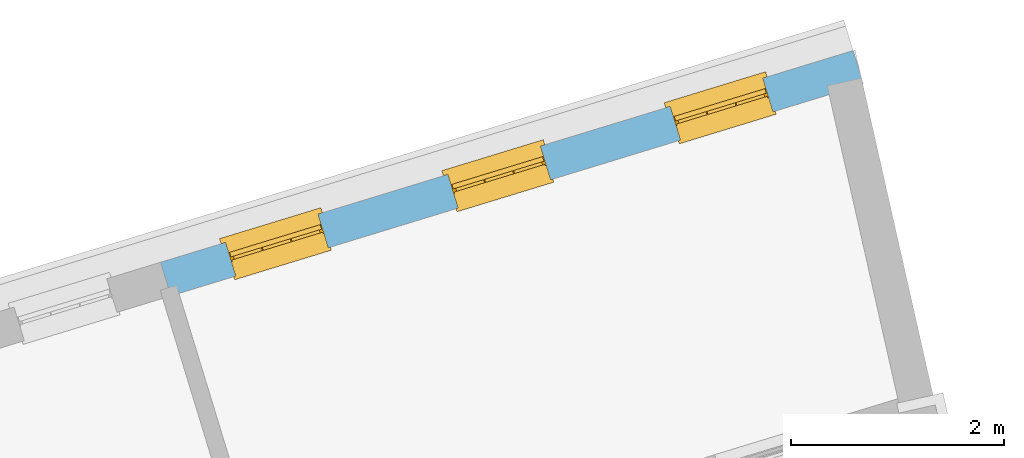
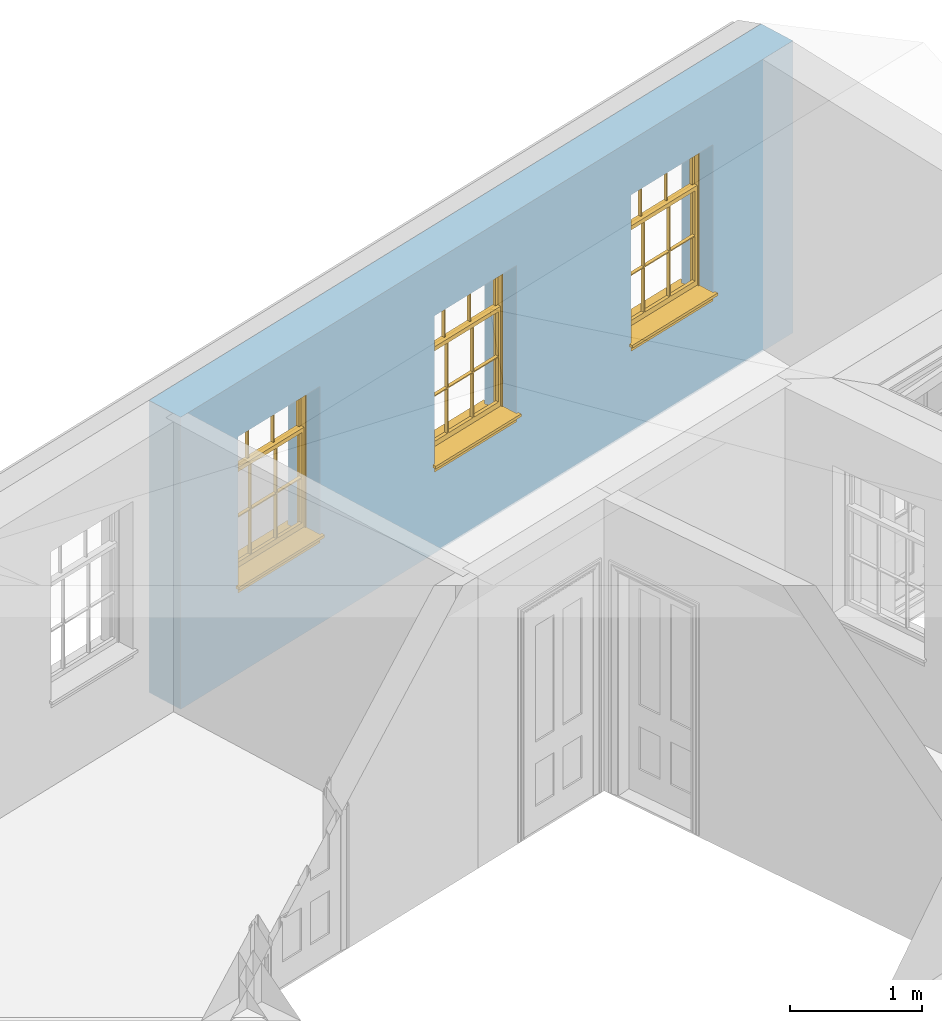
# One storey, part 8 of 10: 3 windows, 3 openings, plus 1 element that does not belong to this part.
"""IFC2X3 building model written with IfcOpenShell, lengths in metres."""

from ifc_helpers import new_model, si_unit, frame, origin, place, context, subcontext, project, spatial, polyline, outline, extrude, faceted_brep, material, layer, layer_set, layer_usage, element, fill, save


model = new_model("IFC2X3")

# Units and contexts
model_context = context("Model", 3, world=origin())
body_context = subcontext(model_context, "Body", "Model", "MODEL_VIEW")
ifc_project = project(units=[si_unit("PLANEANGLEUNIT", "RADIAN"), si_unit("MASSUNIT", "GRAM", prefix="KILO"), si_unit("FORCEUNIT", "NEWTON", prefix="KILO"), si_unit("LENGTHUNIT", "METRE")], contexts=[model_context])

# Site, building, storey
site_placement = place(None, origin())
site = spatial("IfcSite", under=ifc_project, at=site_placement, CompositionType="ELEMENT")
building_placement = place(None, origin())
building = spatial("IfcBuilding", under=site, at=building_placement, Name="Building plot-9", CompositionType="ELEMENT")
storey_placement = place(None, frame((0.0, 0.0, 4.3)))
storey = spatial("IfcBuildingStorey", under=building, at=storey_placement, Name="Floor 1", CompositionType="ELEMENT", Elevation=4.3)

# Wall, openings, windows
ifc_material = material(Name="Masonry")
ifc_layer = layer(ifc_material, 0.33, ventilated=False)
ifc_layer_set = layer_set([ifc_layer], Name="My Wall")
ifc_layer_usage = layer_usage(ifc_layer_set, "AXIS2", "NEGATIVE", 0.08)
wall_placement = place(storey_placement, origin())
wall = element("IfcWallStandardCase", 1, at=wall_placement, inside=storey, material=ifc_layer_usage, Name="exterior", context=body_context, shape_type="SweptSolid", body=[
    extrude(outline(polyline([(40.5718353424252, 23.7164567131035), (40.4753596219165, 24.0320394048854), (33.9739704454548, 22.0445216434864), (34.0704461659636, 21.7289389517045), (40.5718353424252, 23.7164567131035)])), origin(), (0.0, 0.0, 1.0), 2.7),
])
opening_1_placement = place(storey_placement, frame((0.0, 0.0, 0.75)))
opening_1 = element("IfcOpeningElement", 2, at=opening_1_placement, cuts=wall, Name="Opening", ObjectType="Opening", context=body_context, shape_type="SweptSolid", body=[
    extrude(outline(polyline([(39.62768485202, 23.772899609477), (38.7574416716517, 23.5068605014075), (38.8539173921604, 23.1912778096256), (39.7241605725287, 23.457316917695), (39.62768485202, 23.772899609477)])), origin(), (0.0, 0.0, 1.0), 1.445),
])
opening_2_placement = place(storey_placement, frame((0.0, 0.0, 0.75)))
opening_2 = element("IfcOpeningElement", 3, at=opening_2_placement, cuts=wall, Name="Opening", ObjectType="Opening", context=body_context, shape_type="SweptSolid", body=[
    extrude(outline(polyline([(37.5402477254676, 23.1347562446946), (36.6700045450993, 22.8687171366251), (36.766480265608, 22.5531344448432), (37.6367234459763, 22.8191735529127), (37.5402477254676, 23.1347562446946)])), origin(), (0.0, 0.0, 1.0), 1.445),
])
opening_3_placement = place(storey_placement, frame((0.0, 0.0, 0.75)))
opening_3 = element("IfcOpeningElement", 4, at=opening_3_placement, cuts=wall, Name="Opening", ObjectType="Opening", context=body_context, shape_type="SweptSolid", body=[
    extrude(outline(polyline([(35.4528105989152, 22.4966128799123), (34.5825674185469, 22.2305737718428), (34.6790431390556, 21.9149910800609), (35.5492863194239, 22.1810301881304), (35.4528105989152, 22.4966128799123)])), origin(), (0.0, 0.0, 1.0), 1.445),
])
window_1_placement = place(storey_placement, frame((39.7007725190721, 23.5338218126725, 0.75), z_axis=(0.0, 0.0, 1.0), x_axis=(-0.870243180368334, -0.266039108069482, 0.0)))
window_1 = element("IfcWindow", 5, at=window_1_placement, inside=storey, Name="bedroom outside window", OverallHeight=1.445, OverallWidth=0.91, context=body_context, shape_type="Brep", held_by="IfcProductRepresentation", body=[
    faceted_brep([(0.876875, -0.105, 0.999097), (0.876875, -0.105, 1.411875), (0.9, -0.105, 1.435), (0.033125, -0.105, 1.411875), (0.033125, -0.105, 0.999097), (0.01, -0.105, 1.435), (0.033125, -0.135, 1.411875), (0.01, -0.135, 1.435), (0.033125, -0.135, 0.999097), (0.876875, -0.135, 1.411875), (0.876875, -0.135, 0.999097), (0.9, -0.135, 1.435), (0.033125, -0.105, 0.960972), (0.01, -0.105, 0.960972), (0.033125, -0.105, 0.548195), (0.876875, -0.105, 0.960972), (0.876875, -0.105, 0.548195), (0.9, -0.105, 0.960972), (0.876875, -0.105, 0.538195), (0.876875, -0.105, 0.125417), (0.9, -0.105, 0.077167), (0.033125, -0.105, 0.125417), (0.033125, -0.105, 0.538195), (0.01, -0.105, 0.077167), (0.9, -0.135, 0.960972), (0.01, -0.135, 0.960972), (-0.0425, -0.25, 0.01), (-0.0425, -0.3, 0.001667), (0.0, -0.25, 0.01), (0.9525, -0.25, 0.01), (0.91, -0.25, 0.01), (0.9525, -0.3, 0.001667), (-0.02, 0.08, 0.077167), (0.0, 0.08, 0.077167), (-0.02, 0.11, 0.077167), (0.0, -0.06, 0.077167), (0.01, -0.06, 0.077167), (0.91, -0.06, 0.077167), (0.91, 0.08, 0.077167), (0.9, -0.06, 0.077167), (0.93, 0.08, 0.077167), (0.93, 0.11, 0.077167), (0.01, -0.105, 0.999097), (0.01, -0.075, 0.999097), (0.9, -0.105, 0.999097), (0.9, -0.075, 0.999097), (0.876875, -0.075, 0.125417), (0.876875, -0.075, 0.538195), (0.9, -0.075, 0.077167), (0.876875, -0.075, 0.548195), (0.876875, -0.075, 0.960972), (0.033125, -0.075, 0.125417), (0.01, -0.075, 0.077167), (0.033125, -0.075, 0.538195), (0.033125, -0.075, 0.960972), (0.033125, -0.075, 0.548195), (-0.02, 0.08, 0.052167), (-0.02, 0.11, 0.052167), (0.93, 0.11, 0.052167), (0.93, 0.08, 0.052167), (0.91, 0.08, 0.052167), (0.0, 0.08, 0.052167), (0.91, -0.15, 0.026667), (0.0, -0.15, 0.026667), (-0.0425, -0.3, -0.123333), (0.9525, -0.3, -0.123333), (-0.0425, -0.25, -0.123333), (0.9525, -0.25, -0.123333), (0.01, -0.06, 1.435), (0.9, -0.06, 1.435), (0.0, -0.06, 1.445), (0.91, -0.06, 1.445), (0.01, -0.15, 0.077167), (0.9, -0.15, 0.077167), (0.592292, -0.105, 0.125417), (0.592292, -0.075, 0.125417), (0.317708, -0.075, 0.125417), (0.317708, -0.105, 0.125417), (0.592292, -0.105, 0.548195), (0.317708, -0.105, 0.548195), (0.317708, -0.105, 0.538195), (0.592292, -0.105, 0.538195), (0.592292, -0.075, 0.548195), (0.317708, -0.075, 0.548195), (0.602292, -0.075, 0.548195), (0.602292, -0.105, 0.548195), (0.317708, -0.075, 0.538195), (0.307708, -0.075, 0.125417), (0.307708, -0.075, 0.538195), (0.602292, -0.075, 0.538195), (0.602292, -0.075, 0.125417), (0.592292, -0.075, 0.538195), (0.307708, -0.075, 0.548195), (0.317708, -0.075, 0.960972), (0.307708, -0.075, 0.960972), (0.602292, -0.075, 0.960972), (0.592292, -0.075, 0.960972), (0.307708, -0.105, 0.538195), (0.307708, -0.105, 0.125417), (0.307708, -0.105, 0.548195), (0.307708, -0.105, 0.960972), (0.592292, -0.105, 0.960972), (0.317708, -0.105, 0.960972), (0.602292, -0.105, 0.960972), (0.602292, -0.105, 0.538195), (0.602292, -0.105, 0.125417), (0.317708, -0.135, 1.411875), (0.307708, -0.135, 1.411875), (0.307708, -0.135, 0.999097), (0.317708, -0.135, 0.999097), (0.602292, -0.135, 1.411875), (0.592292, -0.135, 1.411875), (0.592292, -0.135, 0.999097), (0.602292, -0.135, 0.999097), (0.317708, -0.105, 0.999097), (0.307708, -0.105, 0.999097), (0.307708, -0.105, 1.411875), (0.317708, -0.105, 1.411875), (0.602292, -0.105, 0.999097), (0.592292, -0.105, 0.999097), (0.592292, -0.105, 1.411875), (0.602292, -0.105, 1.411875), (0.91, -0.15, 1.445), (0.9, -0.15, 1.435), (0.01, -0.15, 1.435), (0.0, -0.15, 1.445), (0.91, -0.25, 0.0), (0.0, -0.25, 0.0), (0.91, 0.08, 0.0), (0.0, 0.08, 0.0)], [[[0, 1, 2]], [[3, 4, 5]], [[6, 7, 8]], [[9, 10, 11]], [[12, 13, 14]], [[15, 16, 17]], [[18, 19, 20]], [[21, 22, 23]], [[24, 15, 17]], [[13, 12, 25]], [[26, 27, 28]], [[29, 30, 31]], [[32, 33, 34]], [[35, 36, 33]], [[37, 38, 39]], [[40, 41, 38]], [[42, 4, 43]], [[44, 45, 0]], [[46, 47, 48]], [[49, 50, 45]], [[51, 52, 53]], [[54, 55, 43]], [[38, 33, 36, 39]], [[41, 34, 33, 38]], [[56, 32, 34, 57]], [[57, 34, 41, 58]], [[58, 41, 40, 59]], [[57, 58, 60, 61]], [[52, 48, 39, 36]], [[62, 63, 28, 30]], [[27, 31, 30, 28]], [[27, 64, 65, 31]], [[66, 67, 65, 64]], [[2, 5, 68, 69]], [[68, 70, 71, 69]], [[20, 23, 72, 73]], [[73, 72, 63, 62]], [[74, 75, 76, 77]], [[78, 79, 80, 81]], [[78, 82, 83, 79]], [[16, 49, 84, 85]], [[86, 76, 87, 88]], [[89, 90, 75, 91]], [[92, 88, 53, 55]], [[82, 91, 86, 83]], [[93, 83, 92, 94]], [[95, 84, 82, 96]], [[89, 84, 49, 47]], [[97, 88, 87, 98]], [[22, 53, 88, 97]], [[81, 91, 75, 74]], [[80, 86, 91, 81]], [[77, 76, 86, 80]], [[99, 92, 55, 14]], [[100, 94, 92, 99]], [[101, 96, 82, 78]], [[79, 83, 93, 102]], [[85, 84, 95, 103]], [[104, 89, 47, 18]], [[105, 90, 89, 104]], [[104, 18, 16, 85]], [[80, 97, 98, 77]], [[104, 81, 74, 105]], [[103, 101, 78, 85]], [[99, 14, 22, 97]], [[102, 100, 99, 79]], [[106, 107, 108, 109]], [[110, 111, 112, 113]], [[114, 115, 116, 117]], [[118, 119, 120, 121]], [[107, 116, 115, 108]], [[111, 120, 119, 112]], [[109, 114, 117, 106]], [[113, 118, 121, 110]], [[85, 78, 81, 104]], [[84, 89, 91, 82]], [[83, 86, 88, 92]], [[79, 99, 97, 80]], [[109, 112, 119, 114]], [[102, 93, 96, 101]], [[106, 117, 120, 111]], [[98, 87, 51, 21]], [[6, 3, 116, 107]], [[110, 121, 1, 9]], [[19, 46, 90, 105]], [[26, 66, 64, 27]], [[29, 31, 65, 67]], [[25, 24, 112, 109]], [[11, 7, 106, 111]], [[75, 48, 52, 76]], [[43, 45, 96, 93]], [[45, 43, 114, 119]], [[5, 2, 120, 117]], [[24, 25, 102, 101]], [[42, 5, 4]], [[2, 44, 0]], [[49, 45, 48, 47]], [[52, 43, 55, 53]], [[14, 13, 23, 22]], [[20, 17, 16, 18]], [[24, 11, 10]], [[25, 8, 7]], [[8, 4, 3, 6]], [[9, 1, 0, 10]], [[15, 50, 49, 16]], [[18, 47, 46, 19]], [[21, 51, 53, 22]], [[14, 55, 54, 12]], [[44, 2, 69, 45]], [[68, 5, 42, 43]], [[36, 35, 70, 68]], [[39, 69, 71, 37]], [[62, 122, 123, 73]], [[63, 72, 124, 125]], [[8, 108, 115, 4]], [[113, 10, 0, 118]], [[94, 100, 12, 54]], [[17, 20, 73, 24]], [[72, 23, 13, 25]], [[52, 36, 68, 43]], [[69, 39, 48, 45]], [[11, 24, 73, 123]], [[7, 124, 72, 25]], [[23, 77, 98]], [[98, 21, 23]], [[105, 74, 20]], [[20, 19, 105]], [[20, 74, 77, 23]], [[113, 112, 24]], [[24, 10, 113]], [[25, 109, 108]], [[108, 8, 25]], [[110, 9, 11]], [[11, 111, 110]], [[7, 6, 107]], [[107, 106, 7]], [[5, 117, 116]], [[116, 3, 5]], [[121, 120, 2]], [[2, 1, 121]], [[11, 123, 124, 7]], [[122, 125, 124, 123]], [[43, 93, 94]], [[94, 54, 43]], [[96, 45, 95]], [[50, 95, 45]], [[15, 103, 95, 50]], [[48, 75, 90]], [[90, 46, 48]], [[87, 76, 52]], [[52, 51, 87]], [[103, 15, 24]], [[24, 101, 103]], [[100, 102, 25]], [[25, 12, 100]], [[115, 114, 43]], [[43, 4, 115]], [[118, 0, 45]], [[45, 119, 118]], [[71, 70, 125, 122]], [[70, 35, 63, 125]], [[122, 62, 37, 71]], [[126, 67, 66, 127]], [[60, 58, 59]], [[38, 60, 59, 40]], [[61, 56, 57]], [[32, 56, 61, 33]], [[61, 60, 128, 129]], [[62, 60, 38, 37]], [[126, 128, 60, 62]], [[33, 61, 63, 35]], [[61, 129, 127, 63]], [[128, 126, 127, 129]], [[28, 127, 66, 26]], [[63, 127, 28]], [[29, 67, 126, 30]], [[30, 126, 62]]]),
])
fill(opening_1, window_1)
window_2_placement = place(storey_placement, frame((37.6133353925197, 22.8956784478901, 0.75), z_axis=(0.0, 0.0, 1.0), x_axis=(-0.870243180368334, -0.266039108069482, 0.0)))
window_2 = element("IfcWindow", 6, at=window_2_placement, inside=storey, Name="bedroom outside window", OverallHeight=1.445, OverallWidth=0.91, context=body_context, shape_type="Brep", held_by="IfcProductRepresentation", body=[
    faceted_brep([(0.876875, -0.105, 0.999097), (0.876875, -0.105, 1.411875), (0.9, -0.105, 1.435), (0.033125, -0.105, 1.411875), (0.033125, -0.105, 0.999097), (0.01, -0.105, 1.435), (0.033125, -0.135, 1.411875), (0.01, -0.135, 1.435), (0.033125, -0.135, 0.999097), (0.876875, -0.135, 1.411875), (0.876875, -0.135, 0.999097), (0.9, -0.135, 1.435), (0.033125, -0.105, 0.960972), (0.01, -0.105, 0.960972), (0.033125, -0.105, 0.548195), (0.876875, -0.105, 0.960972), (0.876875, -0.105, 0.548195), (0.9, -0.105, 0.960972), (0.876875, -0.105, 0.538195), (0.876875, -0.105, 0.125417), (0.9, -0.105, 0.077167), (0.033125, -0.105, 0.125417), (0.033125, -0.105, 0.538195), (0.01, -0.105, 0.077167), (0.9, -0.135, 0.960972), (0.01, -0.135, 0.960972), (-0.0425, -0.25, 0.01), (-0.0425, -0.3, 0.001667), (0.0, -0.25, 0.01), (0.9525, -0.25, 0.01), (0.91, -0.25, 0.01), (0.9525, -0.3, 0.001667), (-0.02, 0.08, 0.077167), (0.0, 0.08, 0.077167), (-0.02, 0.11, 0.077167), (0.0, -0.06, 0.077167), (0.01, -0.06, 0.077167), (0.91, -0.06, 0.077167), (0.91, 0.08, 0.077167), (0.9, -0.06, 0.077167), (0.93, 0.08, 0.077167), (0.93, 0.11, 0.077167), (0.01, -0.105, 0.999097), (0.01, -0.075, 0.999097), (0.9, -0.105, 0.999097), (0.9, -0.075, 0.999097), (0.876875, -0.075, 0.125417), (0.876875, -0.075, 0.538195), (0.9, -0.075, 0.077167), (0.876875, -0.075, 0.548195), (0.876875, -0.075, 0.960972), (0.033125, -0.075, 0.125417), (0.01, -0.075, 0.077167), (0.033125, -0.075, 0.538195), (0.033125, -0.075, 0.960972), (0.033125, -0.075, 0.548195), (-0.02, 0.08, 0.052167), (-0.02, 0.11, 0.052167), (0.93, 0.11, 0.052167), (0.93, 0.08, 0.052167), (0.91, 0.08, 0.052167), (0.0, 0.08, 0.052167), (0.91, -0.15, 0.026667), (0.0, -0.15, 0.026667), (-0.0425, -0.3, -0.123333), (0.9525, -0.3, -0.123333), (-0.0425, -0.25, -0.123333), (0.9525, -0.25, -0.123333), (0.01, -0.06, 1.435), (0.9, -0.06, 1.435), (0.0, -0.06, 1.445), (0.91, -0.06, 1.445), (0.01, -0.15, 0.077167), (0.9, -0.15, 0.077167), (0.592292, -0.105, 0.125417), (0.592292, -0.075, 0.125417), (0.317708, -0.075, 0.125417), (0.317708, -0.105, 0.125417), (0.592292, -0.105, 0.548195), (0.317708, -0.105, 0.548195), (0.317708, -0.105, 0.538195), (0.592292, -0.105, 0.538195), (0.592292, -0.075, 0.548195), (0.317708, -0.075, 0.548195), (0.602292, -0.075, 0.548195), (0.602292, -0.105, 0.548195), (0.317708, -0.075, 0.538195), (0.307708, -0.075, 0.125417), (0.307708, -0.075, 0.538195), (0.602292, -0.075, 0.538195), (0.602292, -0.075, 0.125417), (0.592292, -0.075, 0.538195), (0.307708, -0.075, 0.548195), (0.317708, -0.075, 0.960972), (0.307708, -0.075, 0.960972), (0.602292, -0.075, 0.960972), (0.592292, -0.075, 0.960972), (0.307708, -0.105, 0.538195), (0.307708, -0.105, 0.125417), (0.307708, -0.105, 0.548195), (0.307708, -0.105, 0.960972), (0.592292, -0.105, 0.960972), (0.317708, -0.105, 0.960972), (0.602292, -0.105, 0.960972), (0.602292, -0.105, 0.538195), (0.602292, -0.105, 0.125417), (0.317708, -0.135, 1.411875), (0.307708, -0.135, 1.411875), (0.307708, -0.135, 0.999097), (0.317708, -0.135, 0.999097), (0.602292, -0.135, 1.411875), (0.592292, -0.135, 1.411875), (0.592292, -0.135, 0.999097), (0.602292, -0.135, 0.999097), (0.317708, -0.105, 0.999097), (0.307708, -0.105, 0.999097), (0.307708, -0.105, 1.411875), (0.317708, -0.105, 1.411875), (0.602292, -0.105, 0.999097), (0.592292, -0.105, 0.999097), (0.592292, -0.105, 1.411875), (0.602292, -0.105, 1.411875), (0.91, -0.15, 1.445), (0.9, -0.15, 1.435), (0.01, -0.15, 1.435), (0.0, -0.15, 1.445), (0.91, -0.25, 0.0), (0.0, -0.25, 0.0), (0.91, 0.08, 0.0), (0.0, 0.08, 0.0)], [[[0, 1, 2]], [[3, 4, 5]], [[6, 7, 8]], [[9, 10, 11]], [[12, 13, 14]], [[15, 16, 17]], [[18, 19, 20]], [[21, 22, 23]], [[24, 15, 17]], [[13, 12, 25]], [[26, 27, 28]], [[29, 30, 31]], [[32, 33, 34]], [[35, 36, 33]], [[37, 38, 39]], [[40, 41, 38]], [[42, 4, 43]], [[44, 45, 0]], [[46, 47, 48]], [[49, 50, 45]], [[51, 52, 53]], [[54, 55, 43]], [[38, 33, 36, 39]], [[41, 34, 33, 38]], [[56, 32, 34, 57]], [[57, 34, 41, 58]], [[58, 41, 40, 59]], [[57, 58, 60, 61]], [[52, 48, 39, 36]], [[62, 63, 28, 30]], [[27, 31, 30, 28]], [[27, 64, 65, 31]], [[66, 67, 65, 64]], [[2, 5, 68, 69]], [[68, 70, 71, 69]], [[20, 23, 72, 73]], [[73, 72, 63, 62]], [[74, 75, 76, 77]], [[78, 79, 80, 81]], [[78, 82, 83, 79]], [[16, 49, 84, 85]], [[86, 76, 87, 88]], [[89, 90, 75, 91]], [[92, 88, 53, 55]], [[82, 91, 86, 83]], [[93, 83, 92, 94]], [[95, 84, 82, 96]], [[89, 84, 49, 47]], [[97, 88, 87, 98]], [[22, 53, 88, 97]], [[81, 91, 75, 74]], [[80, 86, 91, 81]], [[77, 76, 86, 80]], [[99, 92, 55, 14]], [[100, 94, 92, 99]], [[101, 96, 82, 78]], [[79, 83, 93, 102]], [[85, 84, 95, 103]], [[104, 89, 47, 18]], [[105, 90, 89, 104]], [[104, 18, 16, 85]], [[80, 97, 98, 77]], [[104, 81, 74, 105]], [[103, 101, 78, 85]], [[99, 14, 22, 97]], [[102, 100, 99, 79]], [[106, 107, 108, 109]], [[110, 111, 112, 113]], [[114, 115, 116, 117]], [[118, 119, 120, 121]], [[107, 116, 115, 108]], [[111, 120, 119, 112]], [[109, 114, 117, 106]], [[113, 118, 121, 110]], [[85, 78, 81, 104]], [[84, 89, 91, 82]], [[83, 86, 88, 92]], [[79, 99, 97, 80]], [[109, 112, 119, 114]], [[102, 93, 96, 101]], [[106, 117, 120, 111]], [[98, 87, 51, 21]], [[6, 3, 116, 107]], [[110, 121, 1, 9]], [[19, 46, 90, 105]], [[26, 66, 64, 27]], [[29, 31, 65, 67]], [[25, 24, 112, 109]], [[11, 7, 106, 111]], [[75, 48, 52, 76]], [[43, 45, 96, 93]], [[45, 43, 114, 119]], [[5, 2, 120, 117]], [[24, 25, 102, 101]], [[42, 5, 4]], [[2, 44, 0]], [[49, 45, 48, 47]], [[52, 43, 55, 53]], [[14, 13, 23, 22]], [[20, 17, 16, 18]], [[24, 11, 10]], [[25, 8, 7]], [[8, 4, 3, 6]], [[9, 1, 0, 10]], [[15, 50, 49, 16]], [[18, 47, 46, 19]], [[21, 51, 53, 22]], [[14, 55, 54, 12]], [[44, 2, 69, 45]], [[68, 5, 42, 43]], [[36, 35, 70, 68]], [[39, 69, 71, 37]], [[62, 122, 123, 73]], [[63, 72, 124, 125]], [[8, 108, 115, 4]], [[113, 10, 0, 118]], [[94, 100, 12, 54]], [[17, 20, 73, 24]], [[72, 23, 13, 25]], [[52, 36, 68, 43]], [[69, 39, 48, 45]], [[11, 24, 73, 123]], [[7, 124, 72, 25]], [[23, 77, 98]], [[98, 21, 23]], [[105, 74, 20]], [[20, 19, 105]], [[20, 74, 77, 23]], [[113, 112, 24]], [[24, 10, 113]], [[25, 109, 108]], [[108, 8, 25]], [[110, 9, 11]], [[11, 111, 110]], [[7, 6, 107]], [[107, 106, 7]], [[5, 117, 116]], [[116, 3, 5]], [[121, 120, 2]], [[2, 1, 121]], [[11, 123, 124, 7]], [[122, 125, 124, 123]], [[43, 93, 94]], [[94, 54, 43]], [[96, 45, 95]], [[50, 95, 45]], [[15, 103, 95, 50]], [[48, 75, 90]], [[90, 46, 48]], [[87, 76, 52]], [[52, 51, 87]], [[103, 15, 24]], [[24, 101, 103]], [[100, 102, 25]], [[25, 12, 100]], [[115, 114, 43]], [[43, 4, 115]], [[118, 0, 45]], [[45, 119, 118]], [[71, 70, 125, 122]], [[70, 35, 63, 125]], [[122, 62, 37, 71]], [[126, 67, 66, 127]], [[60, 58, 59]], [[38, 60, 59, 40]], [[61, 56, 57]], [[32, 56, 61, 33]], [[61, 60, 128, 129]], [[62, 60, 38, 37]], [[126, 128, 60, 62]], [[33, 61, 63, 35]], [[61, 129, 127, 63]], [[128, 126, 127, 129]], [[28, 127, 66, 26]], [[63, 127, 28]], [[29, 67, 126, 30]], [[30, 126, 62]]]),
])
fill(opening_2, window_2)
window_3_placement = place(storey_placement, frame((35.5258982659673, 22.2575350831078, 0.75), z_axis=(0.0, 0.0, 1.0), x_axis=(-0.870243180368334, -0.266039108069482, 0.0)))
window_3 = element("IfcWindow", 7, at=window_3_placement, inside=storey, Name="bedroom outside window", OverallHeight=1.445, OverallWidth=0.91, context=body_context, shape_type="Brep", held_by="IfcProductRepresentation", body=[
    faceted_brep([(0.876875, -0.105, 0.999097), (0.876875, -0.105, 1.411875), (0.9, -0.105, 1.435), (0.033125, -0.105, 1.411875), (0.033125, -0.105, 0.999097), (0.01, -0.105, 1.435), (0.033125, -0.135, 1.411875), (0.01, -0.135, 1.435), (0.033125, -0.135, 0.999097), (0.876875, -0.135, 1.411875), (0.876875, -0.135, 0.999097), (0.9, -0.135, 1.435), (0.033125, -0.105, 0.960972), (0.01, -0.105, 0.960972), (0.033125, -0.105, 0.548195), (0.876875, -0.105, 0.960972), (0.876875, -0.105, 0.548195), (0.9, -0.105, 0.960972), (0.876875, -0.105, 0.538195), (0.876875, -0.105, 0.125417), (0.9, -0.105, 0.077167), (0.033125, -0.105, 0.125417), (0.033125, -0.105, 0.538195), (0.01, -0.105, 0.077167), (0.9, -0.135, 0.960972), (0.01, -0.135, 0.960972), (-0.0425, -0.25, 0.01), (-0.0425, -0.3, 0.001667), (0.0, -0.25, 0.01), (0.9525, -0.25, 0.01), (0.91, -0.25, 0.01), (0.9525, -0.3, 0.001667), (-0.02, 0.08, 0.077167), (0.0, 0.08, 0.077167), (-0.02, 0.11, 0.077167), (0.0, -0.06, 0.077167), (0.01, -0.06, 0.077167), (0.91, -0.06, 0.077167), (0.91, 0.08, 0.077167), (0.9, -0.06, 0.077167), (0.93, 0.08, 0.077167), (0.93, 0.11, 0.077167), (0.01, -0.105, 0.999097), (0.01, -0.075, 0.999097), (0.9, -0.105, 0.999097), (0.9, -0.075, 0.999097), (0.876875, -0.075, 0.125417), (0.876875, -0.075, 0.538195), (0.9, -0.075, 0.077167), (0.876875, -0.075, 0.548195), (0.876875, -0.075, 0.960972), (0.033125, -0.075, 0.125417), (0.01, -0.075, 0.077167), (0.033125, -0.075, 0.538195), (0.033125, -0.075, 0.960972), (0.033125, -0.075, 0.548195), (-0.02, 0.08, 0.052167), (-0.02, 0.11, 0.052167), (0.93, 0.11, 0.052167), (0.93, 0.08, 0.052167), (0.91, 0.08, 0.052167), (0.0, 0.08, 0.052167), (0.91, -0.15, 0.026667), (0.0, -0.15, 0.026667), (-0.0425, -0.3, -0.123333), (0.9525, -0.3, -0.123333), (-0.0425, -0.25, -0.123333), (0.9525, -0.25, -0.123333), (0.01, -0.06, 1.435), (0.9, -0.06, 1.435), (0.0, -0.06, 1.445), (0.91, -0.06, 1.445), (0.01, -0.15, 0.077167), (0.9, -0.15, 0.077167), (0.592292, -0.105, 0.125417), (0.592292, -0.075, 0.125417), (0.317708, -0.075, 0.125417), (0.317708, -0.105, 0.125417), (0.592292, -0.105, 0.548195), (0.317708, -0.105, 0.548195), (0.317708, -0.105, 0.538195), (0.592292, -0.105, 0.538195), (0.592292, -0.075, 0.548195), (0.317708, -0.075, 0.548195), (0.602292, -0.075, 0.548195), (0.602292, -0.105, 0.548195), (0.317708, -0.075, 0.538195), (0.307708, -0.075, 0.125417), (0.307708, -0.075, 0.538195), (0.602292, -0.075, 0.538195), (0.602292, -0.075, 0.125417), (0.592292, -0.075, 0.538195), (0.307708, -0.075, 0.548195), (0.317708, -0.075, 0.960972), (0.307708, -0.075, 0.960972), (0.602292, -0.075, 0.960972), (0.592292, -0.075, 0.960972), (0.307708, -0.105, 0.538195), (0.307708, -0.105, 0.125417), (0.307708, -0.105, 0.548195), (0.307708, -0.105, 0.960972), (0.592292, -0.105, 0.960972), (0.317708, -0.105, 0.960972), (0.602292, -0.105, 0.960972), (0.602292, -0.105, 0.538195), (0.602292, -0.105, 0.125417), (0.317708, -0.135, 1.411875), (0.307708, -0.135, 1.411875), (0.307708, -0.135, 0.999097), (0.317708, -0.135, 0.999097), (0.602292, -0.135, 1.411875), (0.592292, -0.135, 1.411875), (0.592292, -0.135, 0.999097), (0.602292, -0.135, 0.999097), (0.317708, -0.105, 0.999097), (0.307708, -0.105, 0.999097), (0.307708, -0.105, 1.411875), (0.317708, -0.105, 1.411875), (0.602292, -0.105, 0.999097), (0.592292, -0.105, 0.999097), (0.592292, -0.105, 1.411875), (0.602292, -0.105, 1.411875), (0.91, -0.15, 1.445), (0.9, -0.15, 1.435), (0.01, -0.15, 1.435), (0.0, -0.15, 1.445), (0.91, -0.25, 0.0), (0.0, -0.25, 0.0), (0.91, 0.08, 0.0), (0.0, 0.08, 0.0)], [[[0, 1, 2]], [[3, 4, 5]], [[6, 7, 8]], [[9, 10, 11]], [[12, 13, 14]], [[15, 16, 17]], [[18, 19, 20]], [[21, 22, 23]], [[24, 15, 17]], [[13, 12, 25]], [[26, 27, 28]], [[29, 30, 31]], [[32, 33, 34]], [[35, 36, 33]], [[37, 38, 39]], [[40, 41, 38]], [[42, 4, 43]], [[44, 45, 0]], [[46, 47, 48]], [[49, 50, 45]], [[51, 52, 53]], [[54, 55, 43]], [[38, 33, 36, 39]], [[41, 34, 33, 38]], [[56, 32, 34, 57]], [[57, 34, 41, 58]], [[58, 41, 40, 59]], [[57, 58, 60, 61]], [[52, 48, 39, 36]], [[62, 63, 28, 30]], [[27, 31, 30, 28]], [[27, 64, 65, 31]], [[66, 67, 65, 64]], [[2, 5, 68, 69]], [[68, 70, 71, 69]], [[20, 23, 72, 73]], [[73, 72, 63, 62]], [[74, 75, 76, 77]], [[78, 79, 80, 81]], [[78, 82, 83, 79]], [[16, 49, 84, 85]], [[86, 76, 87, 88]], [[89, 90, 75, 91]], [[92, 88, 53, 55]], [[82, 91, 86, 83]], [[93, 83, 92, 94]], [[95, 84, 82, 96]], [[89, 84, 49, 47]], [[97, 88, 87, 98]], [[22, 53, 88, 97]], [[81, 91, 75, 74]], [[80, 86, 91, 81]], [[77, 76, 86, 80]], [[99, 92, 55, 14]], [[100, 94, 92, 99]], [[101, 96, 82, 78]], [[79, 83, 93, 102]], [[85, 84, 95, 103]], [[104, 89, 47, 18]], [[105, 90, 89, 104]], [[104, 18, 16, 85]], [[80, 97, 98, 77]], [[104, 81, 74, 105]], [[103, 101, 78, 85]], [[99, 14, 22, 97]], [[102, 100, 99, 79]], [[106, 107, 108, 109]], [[110, 111, 112, 113]], [[114, 115, 116, 117]], [[118, 119, 120, 121]], [[107, 116, 115, 108]], [[111, 120, 119, 112]], [[109, 114, 117, 106]], [[113, 118, 121, 110]], [[85, 78, 81, 104]], [[84, 89, 91, 82]], [[83, 86, 88, 92]], [[79, 99, 97, 80]], [[109, 112, 119, 114]], [[102, 93, 96, 101]], [[106, 117, 120, 111]], [[98, 87, 51, 21]], [[6, 3, 116, 107]], [[110, 121, 1, 9]], [[19, 46, 90, 105]], [[26, 66, 64, 27]], [[29, 31, 65, 67]], [[25, 24, 112, 109]], [[11, 7, 106, 111]], [[75, 48, 52, 76]], [[43, 45, 96, 93]], [[45, 43, 114, 119]], [[5, 2, 120, 117]], [[24, 25, 102, 101]], [[42, 5, 4]], [[2, 44, 0]], [[49, 45, 48, 47]], [[52, 43, 55, 53]], [[14, 13, 23, 22]], [[20, 17, 16, 18]], [[24, 11, 10]], [[25, 8, 7]], [[8, 4, 3, 6]], [[9, 1, 0, 10]], [[15, 50, 49, 16]], [[18, 47, 46, 19]], [[21, 51, 53, 22]], [[14, 55, 54, 12]], [[44, 2, 69, 45]], [[68, 5, 42, 43]], [[36, 35, 70, 68]], [[39, 69, 71, 37]], [[62, 122, 123, 73]], [[63, 72, 124, 125]], [[8, 108, 115, 4]], [[113, 10, 0, 118]], [[94, 100, 12, 54]], [[17, 20, 73, 24]], [[72, 23, 13, 25]], [[52, 36, 68, 43]], [[69, 39, 48, 45]], [[11, 24, 73, 123]], [[7, 124, 72, 25]], [[23, 77, 98]], [[98, 21, 23]], [[105, 74, 20]], [[20, 19, 105]], [[20, 74, 77, 23]], [[113, 112, 24]], [[24, 10, 113]], [[25, 109, 108]], [[108, 8, 25]], [[110, 9, 11]], [[11, 111, 110]], [[7, 6, 107]], [[107, 106, 7]], [[5, 117, 116]], [[116, 3, 5]], [[121, 120, 2]], [[2, 1, 121]], [[11, 123, 124, 7]], [[122, 125, 124, 123]], [[43, 93, 94]], [[94, 54, 43]], [[96, 45, 95]], [[50, 95, 45]], [[15, 103, 95, 50]], [[48, 75, 90]], [[90, 46, 48]], [[87, 76, 52]], [[52, 51, 87]], [[103, 15, 24]], [[24, 101, 103]], [[100, 102, 25]], [[25, 12, 100]], [[115, 114, 43]], [[43, 4, 115]], [[118, 0, 45]], [[45, 119, 118]], [[71, 70, 125, 122]], [[70, 35, 63, 125]], [[122, 62, 37, 71]], [[126, 67, 66, 127]], [[60, 58, 59]], [[38, 60, 59, 40]], [[61, 56, 57]], [[32, 56, 61, 33]], [[61, 60, 128, 129]], [[62, 60, 38, 37]], [[126, 128, 60, 62]], [[33, 61, 63, 35]], [[61, 129, 127, 63]], [[128, 126, 127, 129]], [[28, 127, 66, 26]], [[63, 127, 28]], [[29, 67, 126, 30]], [[30, 126, 62]]]),
])
fill(opening_3, window_3)

save(model, "model.ifc")
